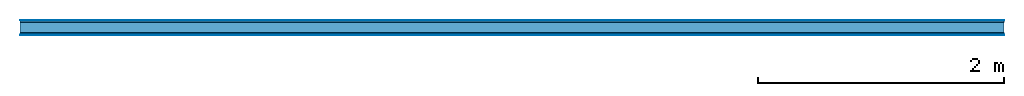
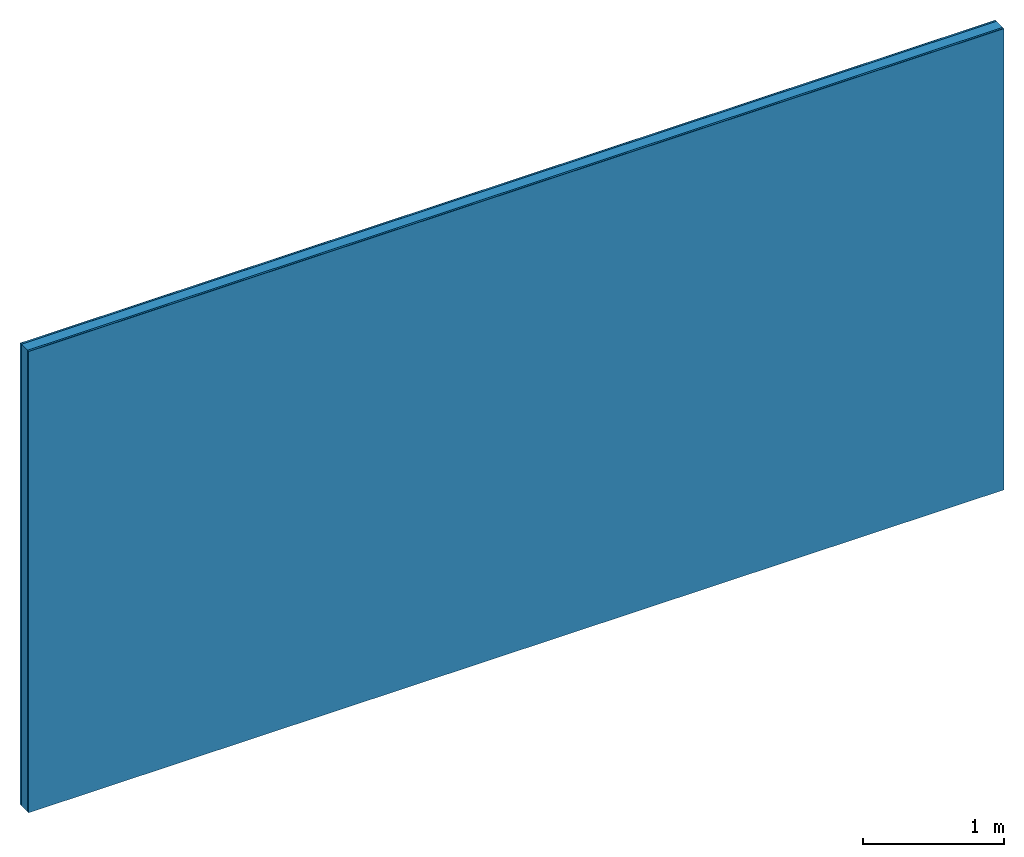
# One storey: 4 plates, 1 member, 1 element without a shape of its own.
"""IFC4 building model written with IfcOpenShell, lengths in metres."""

from ifc_helpers import new_model, si_unit, derived_unit, direction, frame, frame_2d, origin, origin_with_axes, place, context, project, spatial, rectangle, extrude, material, layer, layer_set, type_object, element, aggregate, save


model = new_model("IFC4")

# Units and contexts
plan_context = context("Plan", 3, precision=1e-05, world=origin(), true_north=direction((0.0, 1.0)))
model_context = context("Model", 3, precision=1e-05, world=origin(), true_north=direction((0.0, 1.0)))
ifc_project = project(units=[si_unit("LENGTHUNIT", "METRE"), derived_unit("SOUNDPRESSUREUNIT", [(si_unit("PRESSUREUNIT", "PASCAL", prefix="MICRO"), 0)]), si_unit("ENERGYUNIT", "JOULE", prefix="MEGA"), si_unit("MASSUNIT", "GRAM", prefix="KILO"), derived_unit("THERMALTRANSMITTANCEUNIT", [(si_unit("POWERUNIT", "WATT"), 1), (si_unit("AREAUNIT", "SQUARE_METRE"), -1), (si_unit("THERMODYNAMICTEMPERATUREUNIT", "KELVIN"), -1)]), derived_unit("AREADENSITYUNIT", [(si_unit("MASSUNIT", "GRAM", prefix="KILO"), 1), (si_unit("AREAUNIT", "SQUARE_METRE"), -1)]), derived_unit("USERDEFINED", [(si_unit("ENERGYUNIT", "JOULE", prefix="MEGA"), 1), (si_unit("AREAUNIT", "SQUARE_METRE"), -1)])], contexts=[plan_context, model_context])

# Site, building, storey
site = spatial("IfcSite", under=ifc_project)
building_placement = place(None, origin())
building = spatial("IfcBuilding", under=site, at=building_placement)
storey_placement = place(building_placement, origin())
storey = spatial("IfcBuildingStorey", under=building, at=storey_placement)

# Wall, member, plates
ifc_material_1 = material(Category="04.001")
ifc_layer_1 = layer(ifc_material_1, 0.003, Name="Surface")
ifc_material_2 = material(Name="DFH2IR Knauf Diamant hard- plasterboard", Category="03.007")
ifc_layer_2 = layer(ifc_material_2, 0.015, Name="1st layer")
ifc_material_3 = material(Name="of the art")
ifc_layer_3 = layer(ifc_material_3, 0.0, Name="Bond")
ifc_layer_4 = layer(None, 0.087, Name="Support")
ifc_layer_5 = layer(ifc_material_3, 0.0, Name="Bond")
ifc_layer_6 = layer(ifc_material_2, 0.015, Name="1st layer")
ifc_layer_7 = layer(ifc_material_1, 0.003, Name="Surface")
ifc_layer_set = layer_set([ifc_layer_1, ifc_layer_2, ifc_layer_3, ifc_layer_4, ifc_layer_5, ifc_layer_6, ifc_layer_7])
wall_type = type_object("IfcWallType", Name="C0371", PredefinedType="NOTDEFINED", material=ifc_layer_set)
wall_placement = place(None, frame((0.0, 0.0, 0.0), z_axis=(0.0, -1.0, 0.0), x_axis=(1.0, 0.0, 0.0)))
wall = element("IfcWall", 1, at=wall_placement, inside=storey, type_object=wall_type, material=ifc_layer_set, Name="Wall #1")
ifc_material_4 = material(Name="Solid timber panel")
member_placement = place(wall_placement, origin())
member = element("IfcMember", 2, at=member_placement, material=ifc_material_4, Name="Support", context=plan_context, shape_type="SweptSolid", body=[
    extrude(rectangle(XDim=1.0, YDim=0.087, at=frame_2d((0.5, 0.0435), x_axis=(1.0, 0.0))), frame((0.0, 4.0, 0.018), z_axis=(0.0, -1.0, 0.0), x_axis=(1.0, 0.0, 0.0)), (0.0, 0.0, 1.0), 4.0),
    extrude(rectangle(XDim=1.0, YDim=0.087, at=frame_2d((0.5, 0.0435), x_axis=(1.0, 0.0))), frame((1.0, 4.0, 0.018), z_axis=(0.0, -1.0, 0.0), x_axis=(1.0, 0.0, 0.0)), (0.0, 0.0, 1.0), 4.0),
    extrude(rectangle(XDim=1.0, YDim=0.087, at=frame_2d((0.5, 0.0435), x_axis=(1.0, 0.0))), frame((2.0, 4.0, 0.018), z_axis=(0.0, -1.0, 0.0), x_axis=(1.0, 0.0, 0.0)), (0.0, 0.0, 1.0), 4.0),
    extrude(rectangle(XDim=1.0, YDim=0.087, at=frame_2d((0.5, 0.0435), x_axis=(1.0, 0.0))), frame((3.0, 4.0, 0.018), z_axis=(0.0, -1.0, 0.0), x_axis=(1.0, 0.0, 0.0)), (0.0, 0.0, 1.0), 4.0),
    extrude(rectangle(XDim=1.0, YDim=0.087, at=frame_2d((0.5, 0.0435), x_axis=(1.0, 0.0))), frame((4.0, 4.0, 0.018), z_axis=(0.0, -1.0, 0.0), x_axis=(1.0, 0.0, 0.0)), (0.0, 0.0, 1.0), 4.0),
    extrude(rectangle(XDim=1.0, YDim=0.087, at=frame_2d((0.5, 0.0435), x_axis=(1.0, 0.0))), frame((5.0, 4.0, 0.018), z_axis=(0.0, -1.0, 0.0), x_axis=(1.0, 0.0, 0.0)), (0.0, 0.0, 1.0), 4.0),
    extrude(rectangle(XDim=1.0, YDim=0.087, at=frame_2d((0.5, 0.0435), x_axis=(1.0, 0.0))), frame((6.0, 4.0, 0.018), z_axis=(0.0, -1.0, 0.0), x_axis=(1.0, 0.0, 0.0)), (0.0, 0.0, 1.0), 4.0),
    extrude(rectangle(XDim=1.0, YDim=0.087, at=frame_2d((0.5, 0.0435), x_axis=(1.0, 0.0))), frame((7.0, 4.0, 0.018), z_axis=(0.0, -1.0, 0.0), x_axis=(1.0, 0.0, 0.0)), (0.0, 0.0, 1.0), 4.0),
])
plate_1_placement = place(wall_placement, origin())
plate_1 = element("IfcPlate", 3, at=plate_1_placement, material=ifc_material_1, Name="Surface", context=plan_context, shape_type="SweptSolid", body=[
    extrude(rectangle(XDim=8.0, YDim=4.0, at=frame_2d((4.0, 2.0), x_axis=(1.0, 0.0))), origin_with_axes(), (0.0, 0.0, 1.0), 0.003),
])
plate_2_placement = place(wall_placement, origin())
plate_2 = element("IfcPlate", 4, at=plate_2_placement, material=ifc_material_2, Name="1st layer", context=plan_context, shape_type="SweptSolid", body=[
    extrude(rectangle(XDim=8.0, YDim=4.0, at=frame_2d((4.0, 2.0), x_axis=(1.0, 0.0))), frame((0.0, 0.0, 0.003), z_axis=(0.0, 0.0, 1.0), x_axis=(1.0, 0.0, 0.0)), (0.0, 0.0, 1.0), 0.015),
])
plate_3_placement = place(wall_placement, origin())
plate_3 = element("IfcPlate", 5, at=plate_3_placement, material=ifc_material_2, Name="1st layer", context=plan_context, shape_type="SweptSolid", body=[
    extrude(rectangle(XDim=8.0, YDim=4.0, at=frame_2d((4.0, 2.0), x_axis=(1.0, 0.0))), frame((0.0, 0.0, 0.105), z_axis=(0.0, 0.0, 1.0), x_axis=(1.0, 0.0, 0.0)), (0.0, 0.0, 1.0), 0.015),
])
plate_4_placement = place(wall_placement, origin())
plate_4 = element("IfcPlate", 6, at=plate_4_placement, material=ifc_material_1, Name="Surface", context=plan_context, shape_type="SweptSolid", body=[
    extrude(rectangle(XDim=8.0, YDim=4.0, at=frame_2d((4.0, 2.0), x_axis=(1.0, 0.0))), frame((0.0, 0.0, 0.12), z_axis=(0.0, 0.0, 1.0), x_axis=(1.0, 0.0, 0.0)), (0.0, 0.0, 1.0), 0.003),
])
aggregate(wall, [plate_1, plate_2, member, plate_3, plate_4])

save(model, "model.ifc")
